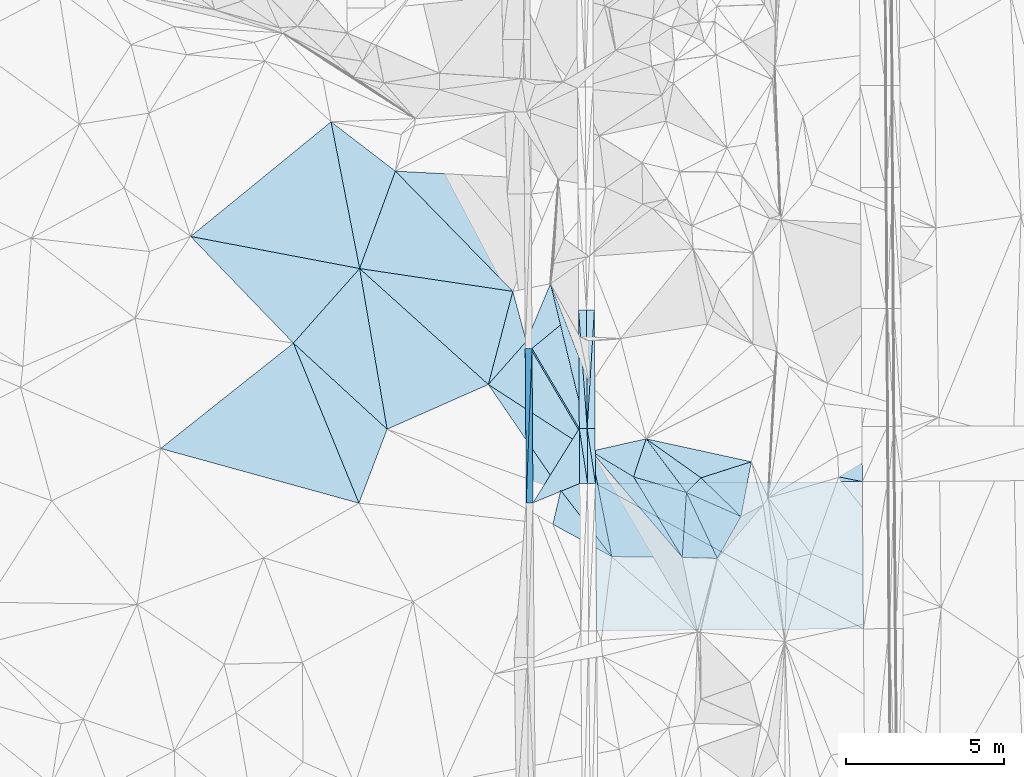
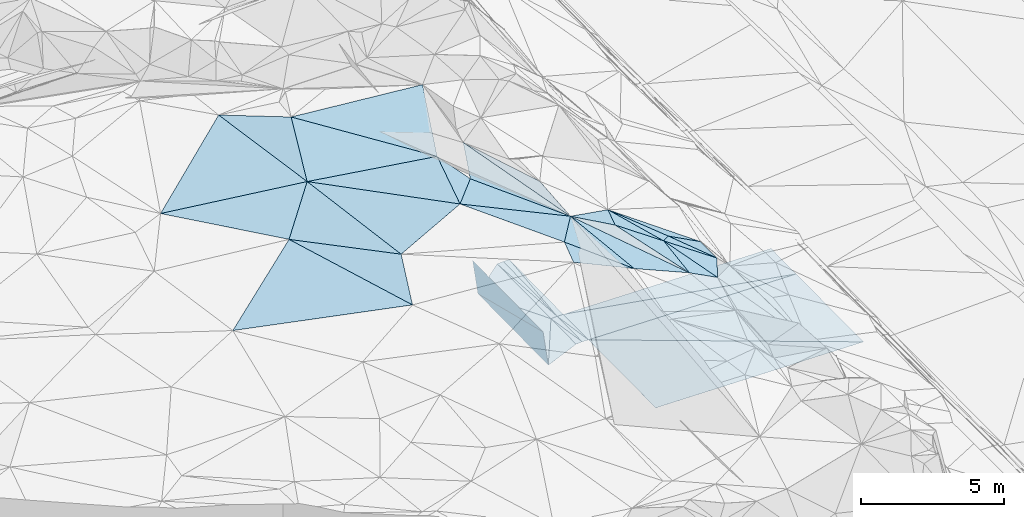
# One storey, part 52 of 275: 45 plates.
"""IFC2X3 building model written with IfcOpenShell, lengths in millimetres."""

from ifc_helpers import new_model, si_unit, frame, origin_with_axes, place, context, subcontext, project, spatial, polyline, outline, extrude, material, type_object, element, save


model = new_model("IFC2X3")

# Units and contexts
model_context = context("Model", 3, precision=1e-05, world=origin_with_axes())
body_context = subcontext(model_context, "Body", "Model", "MODEL_VIEW")
ifc_project = project(units=[si_unit("LENGTHUNIT", "METRE", prefix="MILLI"), si_unit("AREAUNIT", "SQUARE_METRE"), si_unit("VOLUMEUNIT", "CUBIC_METRE"), si_unit("MASSUNIT", "GRAM", prefix="KILO"), si_unit("TIMEUNIT", "SECOND"), si_unit("PLANEANGLEUNIT", "RADIAN"), si_unit("SOLIDANGLEUNIT", "STERADIAN"), si_unit("THERMODYNAMICTEMPERATUREUNIT", "DEGREE_CELSIUS"), si_unit("LUMINOUSINTENSITYUNIT", "LUMEN")], contexts=[model_context])

# Site, building, storey
site_placement = place(None, origin_with_axes())
site = spatial("IfcSite", under=ifc_project, at=site_placement, CompositionType="ELEMENT")
building_placement = place(site_placement, origin_with_axes())
building = spatial("IfcBuilding", under=site, at=building_placement, Name="Undefined", CompositionType="ELEMENT")
storey_placement = place(building_placement, origin_with_axes())
storey = spatial("IfcBuildingStorey", under=building, at=storey_placement, Name="Undefined", CompositionType="ELEMENT", Elevation=0.0)

# Plates
ifc_material = material()
plate_type_1 = type_object("IfcPlateType", PredefinedType="NOTDEFINED")
plate_1_placement = place(storey_placement, frame((-105646.099505865, 40971.8462119818, 43556.70029199), z_axis=(-0.989944103997559, -0.00332123329440851, -0.14142008474709), x_axis=(0.0358624279315071, 0.961171665387579, -0.273610884138268)))
element("IfcPlate", 1, at=plate_1_placement, inside=storey, type_object=plate_type_1, material=ifc_material, Name="00_PR", context=body_context, shape_type="SweptSolid", body=[
    extrude(outline(polyline([(0.0, 0.0), (5083.78515625, -1.32131390273571e-08), (419.531982421875, 1455.99145507813), (0.0, 0.0)])), frame((-8.85201319254618e-08, 2.18876761149539e-07, -0.5000001331573), z_axis=(0.0, 0.0, 1.0), x_axis=(1.0, 0.0, 0.0)), (0.0, 0.0, 1.0), 1.0),
])
plate_2_placement = place(storey_placement, frame((-105463.782624478, 45858.2366308614, 42165.7212907842), z_axis=(-0.989943962731885, -0.00332151817622942, -0.141421066916132), x_axis=(-0.0358624279064692, -0.96117166539395, 0.273610884119171)))
element("IfcPlate", 2, at=plate_2_placement, inside=storey, type_object=plate_type_1, material=ifc_material, Name="00_PR", context=body_context, shape_type="SweptSolid", body=[
    extrude(outline(polyline([(0.0, 0.0), (5083.78515625, -1.32131390273571e-08), (419.365844726563, 1456.03942871094), (0.0, 0.0)])), frame((-8.85201319254618e-08, 2.18876761149539e-07, -0.5000001331573), z_axis=(0.0, 0.0, 1.0), x_axis=(1.0, 0.0, 0.0)), (0.0, 0.0, 1.0), 1.0),
])
plate_type_2 = type_object("IfcPlateType", PredefinedType="NOTDEFINED")
plate_3_placement = place(storey_placement, frame((-103990.523976332, 47065.1459891625, 42193.5847640557), z_axis=(0.0497826913017359, 0.0238959430009052, -0.998474169698372), x_axis=(0.998734720942488, 0.00593198109891951, 0.0499376489652106)))
element("IfcPlate", 3, at=plate_3_placement, inside=storey, type_object=plate_type_2, material=ifc_material, Name="00_PR", context=body_context, shape_type="SweptSolid", body=[
    extrude(outline(polyline([(0.0, 0.0), (250.312118530273, 2.47382558882236e-10), (247.060760498047, 3738.74194335938), (0.0, 0.0)])), frame((-8.85201319254618e-08, 2.18876761149539e-07, -0.5000001331573), z_axis=(0.0, 0.0, 1.0), x_axis=(1.0, 0.0, 0.0)), (0.0, 0.0, 1.0), 1.0),
])
plate_4_placement = place(storey_placement, frame((-103990.523976332, 47065.1459891625, 42193.5847640557), z_axis=(0.049768066755997, 0.0238948883773834, -0.998474923991986), x_axis=(0.0729547701272873, -0.997130130226258, -0.0202263419985308)))
element("IfcPlate", 4, at=plate_4_placement, inside=storey, type_object=plate_type_2, material=ifc_material, Name="00_PR", context=body_context, shape_type="SweptSolid", body=[
    extrude(outline(polyline([(0.0, 0.0), (3746.89599609375, 9.83709469437599e-09), (3730.54565429688, 249.77783203125), (0.0, 0.0)])), frame((-8.85201319254618e-08, 2.18876761149539e-07, -0.5000001331573), z_axis=(0.0, 0.0, 1.0), x_axis=(1.0, 0.0, 0.0)), (0.0, 0.0, 1.0), 1.0),
])
plate_5_placement = place(storey_placement, frame((-103967.16475753, 43327.3619378726, 42105.2987347307), z_axis=(0.0497883116718001, 0.0212555803372837, -0.998533586979125), x_axis=(0.998730855208098, 0.00655097410648451, 0.0499375969942156)))
element("IfcPlate", 5, at=plate_5_placement, inside=storey, type_object=plate_type_2, material=ifc_material, Name="00_PR", context=body_context, shape_type="SweptSolid", body=[
    extrude(outline(polyline([(0.0, 0.0), (250.312408447266, 1.29512045532465e-09), (248.740264892578, 1744.41296386719), (0.0, 0.0)])), frame((-8.85201319254618e-08, 2.18876761149539e-07, -0.5000001331573), z_axis=(0.0, 0.0, 1.0), x_axis=(1.0, 0.0, 0.0)), (0.0, 0.0, 1.0), 1.0),
])
plate_6_placement = place(storey_placement, frame((-103717.204999784, 43329.0015019707, 42117.7982104871), z_axis=(-0.0201285348470249, 0.0208096383223424, -0.99958081265989), x_axis=(0.999778552913114, 0.00655785011376735, -0.0199959930197069)))
element("IfcPlate", 6, at=plate_6_placement, inside=storey, type_object=plate_type_2, material=ifc_material, Name="00_PR", context=body_context, shape_type="SweptSolid", body=[
    extrude(outline(polyline([(0.0, 0.0), (250.050094604492, -1.09139364212751e-09), (251.033966064453, 1744.34130859375), (0.0, 0.0)])), frame((-8.85201319254618e-08, 2.18876761149539e-07, -0.5000001331573), z_axis=(0.0, 0.0, 1.0), x_axis=(1.0, 0.0, 0.0)), (0.0, 0.0, 1.0), 1.0),
])
plate_7_placement = place(storey_placement, frame((-103490.567670264, 47068.1145608061, 42201.0842400779), z_axis=(-0.0201301595601197, 0.0234837584701815, -0.999521530415528), x_axis=(-0.0604866279020692, -0.997921482323828, -0.0222279770030963)))
element("IfcPlate", 7, at=plate_7_placement, inside=storey, type_object=plate_type_2, material=ifc_material, Name="00_PR", context=body_context, shape_type="SweptSolid", body=[
    extrude(outline(polyline([(0.0, 0.0), (3746.89965820313, -5.96628524363041e-09), (16.4911136627197, 249.505844116211), (0.0, 0.0)])), frame((-8.85201319254618e-08, 2.18876761149539e-07, -0.5000001331573), z_axis=(0.0, 0.0, 1.0), x_axis=(1.0, 0.0, 0.0)), (0.0, 0.0, 1.0), 1.0),
])
plate_8_placement = place(storey_placement, frame((-103717.205004807, 43329.0028402854, 42117.7982401176), z_axis=(-0.0201448896298397, 0.0234846442214131, -0.999521212835223), x_axis=(0.0604866278932027, 0.997921482324426, 0.0222279770003913)))
element("IfcPlate", 8, at=plate_8_placement, inside=storey, type_object=plate_type_2, material=ifc_material, Name="00_PR", context=body_context, shape_type="SweptSolid", body=[
    extrude(outline(polyline([(0.0, 0.0), (3746.89965820313, -5.96628524363041e-09), (16.6465797424316, 249.495376586914), (0.0, 0.0)])), frame((-8.85201319254618e-08, 2.18876761149539e-07, -0.5000001331573), z_axis=(0.0, 0.0, 1.0), x_axis=(1.0, 0.0, 0.0)), (0.0, 0.0, 1.0), 1.0),
])
plate_9_placement = place(storey_placement, frame((-103455.518130814, 41586.7216911153, 42076.2572102643), z_axis=(-0.0201345410641889, 0.0208087343457324, -0.999580710513695), x_axis=(-0.999776620871527, -0.00684613913005183, 0.0199959680366688)))
element("IfcPlate", 9, at=plate_9_placement, inside=storey, type_object=plate_type_2, material=ifc_material, Name="00_PR", context=body_context, shape_type="SweptSolid", body=[
    extrude(outline(polyline([(0.0, 0.0), (250.050399780273, 6.83940015733242e-10), (250.531173706055, 1744.41357421875), (0.0, 0.0)])), frame((-8.85201319254618e-08, 2.18876761149539e-07, -0.5000001331573), z_axis=(0.0, 0.0, 1.0), x_axis=(1.0, 0.0, 0.0)), (0.0, 0.0, 1.0), 1.0),
])
plate_type_3 = type_object("IfcPlateType", PredefinedType="NOTDEFINED")
plate_10_placement = place(storey_placement, frame((-102939.146189244, 39270.7353602153, 46349.5065492143), z_axis=(-0.0826053856121909, 0.138808484605997, -0.986868053424189), x_axis=(-0.867752438274442, 0.476952593334072, 0.13972089886865)))
element("IfcPlate", 10, at=plate_10_placement, inside=storey, type_object=plate_type_3, material=ifc_material, Name="00", context=body_context, shape_type="SweptSolid", body=[
    extrude(outline(polyline([(0.0, 0.0), (2147.1376953125, -1.00590114016086e-09), (2461.41650390625, 1062.13403320313), (0.0, 0.0)])), frame((-8.85201319254618e-08, 2.18876761149539e-07, -0.5000001331573), z_axis=(0.0, 0.0, 1.0), x_axis=(1.0, 0.0, 0.0)), (0.0, 0.0, 1.0), 1.0),
])
plate_type_4 = type_object("IfcPlateType", PredefinedType="NOTDEFINED")
plate_11_placement = place(storey_placement, frame((-110915.037388213, 48383.8786528723, 47339.5012897801), z_axis=(0.0226269542066406, 0.068628935059666, -0.997385627636526), x_axis=(0.742622411281984, -0.66907387332103, -0.0291908598867195)))
element("IfcPlate", 11, at=plate_11_placement, inside=storey, type_object=plate_type_4, material=ifc_material, Name="00", context=body_context, shape_type="SweptSolid", body=[
    extrude(outline(polyline([(0.0, 0.0), (5481.16796875, -2.38287611864507e-08), (4055.77807617188, 3201.119140625), (0.0, 0.0)])), frame((-8.85201319254618e-08, 2.18876761149539e-07, -0.5000001331573), z_axis=(0.0, 0.0, 1.0), x_axis=(1.0, 0.0, 0.0)), (0.0, 0.0, 1.0), 1.0),
])
plate_type_5 = type_object("IfcPlateType", PredefinedType="NOTDEFINED")
plate_12_placement = place(storey_placement, frame((-105431.325757645, 40973.3478867725, 42056.2711269941), z_axis=(-0.0023716211679166, 0.0222968232700742, -0.999748581937028), x_axis=(-0.00654147009644607, 0.999729657177308, 0.0223119189923385)))
element("IfcPlate", 12, at=plate_12_placement, inside=storey, type_object=plate_type_5, material=ifc_material, Name="00_PR", context=body_context, shape_type="SweptSolid", body=[
    extrude(outline(polyline([(0.0, 0.0), (4886.22265625, 8.78935679793358e-09), (2344.89453125, 1479.509765625), (0.0, 0.0)])), frame((-8.85201319254618e-08, 2.18876761149539e-07, -0.5000001331573), z_axis=(0.0, 0.0, 1.0), x_axis=(1.0, 0.0, 0.0)), (0.0, 0.0, 1.0), 1.0),
])
plate_13_placement = place(storey_placement, frame((-105463.287724358, 45858.2500991869, 42165.2921410413), z_axis=(-0.000145026307554979, 0.0236123931932883, -0.99972117805669), x_axis=(0.773375530053291, 0.633774062177559, 0.0148569049854867)))
element("IfcPlate", 13, at=plate_13_placement, inside=storey, type_object=plate_type_5, material=ifc_material, Name="00_PR", context=body_context, shape_type="SweptSolid", body=[
    extrude(outline(polyline([(0.0, 0.0), (1904.29968261719, -4.26371116191149e-09), (-447.856262207031, 2906.32446289063), (0.0, 0.0)])), frame((-8.85201319254618e-08, 2.18876761149539e-07, -0.5000001331573), z_axis=(0.0, 0.0, 1.0), x_axis=(1.0, 0.0, 0.0)), (0.0, 0.0, 1.0), 1.0),
])
plate_type_6 = type_object("IfcPlateType", PredefinedType="NOTDEFINED")
plate_14_placement = place(storey_placement, frame((-103705.477725775, 41585.010034018, 42081.2577343795), z_axis=(0.0497822401584347, 0.0212546735396291, -0.998533908997352), x_axis=(-0.998728898729701, -0.00684263509403979, -0.0499376129498451)))
element("IfcPlate", 14, at=plate_14_placement, inside=storey, type_object=plate_type_6, material=ifc_material, Name="00_PR", context=body_context, shape_type="SweptSolid", body=[
    extrude(outline(polyline([(0.0, 0.0), (250.31233215332, -1.60071067512035e-10), (248.231567382813, 1744.4853515625), (0.0, 0.0)])), frame((-8.85201319254618e-08, 2.18876761149539e-07, -0.5000001331573), z_axis=(0.0, 0.0, 1.0), x_axis=(1.0, 0.0, 0.0)), (0.0, 0.0, 1.0), 1.0),
])
plate_type_7 = type_object("IfcPlateType", PredefinedType="NOTDEFINED")
plate_15_placement = place(storey_placement, frame((-103955.496871295, 41583.297085441, 42068.7571113255), z_axis=(-0.00019824100908301, 0.0209457045336442, -0.999780595011771), x_axis=(-0.924151662952956, -0.381945772098583, -0.00781863397933819)))
element("IfcPlate", 15, at=plate_15_placement, inside=storey, type_object=plate_type_7, material=ifc_material, Name="00_PR", context=body_context, shape_type="SweptSolid", body=[
    extrude(outline(polyline([(0.0, 0.0), (1596.9541015625, 1.13359419628978e-08), (-655.617858886719, 1616.60107421875), (0.0, 0.0)])), frame((-8.85201319254618e-08, 2.18876761149539e-07, -0.5000001331573), z_axis=(0.0, 0.0, 1.0), x_axis=(1.0, 0.0, 0.0)), (0.0, 0.0, 1.0), 1.0),
])
plate_type_8 = type_object("IfcPlateType", PredefinedType="NOTDEFINED")
plate_16_placement = place(storey_placement, frame((-103467.210276202, 43330.641308768, 42112.7982102375), z_axis=(-0.0201313758675442, 0.0208385412725636, -0.999580153316037), x_axis=(0.999778365282189, 0.00657969213106118, -0.019998199047256)))
element("IfcPlate", 16, at=plate_16_placement, inside=storey, type_object=plate_type_8, material=ifc_material, Name="00_PR", context=body_context, shape_type="SweptSolid", body=[
    extrude(outline(polyline([(0.0, 0.0), (8443.5107421875, -3.54120857082307e-08), (8444.4931640625, 1741.89990234375), (0.0, 0.0)])), frame((-8.85201319254618e-08, 2.18876761149539e-07, -0.5000001331573), z_axis=(0.0, 0.0, 1.0), x_axis=(1.0, 0.0, 0.0)), (0.0, 0.0, 1.0), 1.0),
])
plate_type_9 = type_object("IfcPlateType", PredefinedType="NOTDEFINED")
plate_17_placement = place(storey_placement, frame((-95013.8578508624, 41644.7195649811, 41907.4022094832), z_axis=(-0.0201371647296545, 0.0208095774220167, -0.999580640110726), x_axis=(-0.999776421923135, -0.00686889812441392, 0.0199981100389784)))
element("IfcPlate", 17, at=plate_17_placement, inside=storey, type_object=plate_type_9, material=ifc_material, Name="00_PR", context=body_context, shape_type="SweptSolid", body=[
    extrude(outline(polyline([(0.0, 0.0), (8443.5478515625, -4.53292159363627e-09), (8443.9892578125, 1744.34155273438), (0.0, 0.0)])), frame((-8.85201319254618e-08, 2.18876761149539e-07, -0.5000001331573), z_axis=(0.0, 0.0, 1.0), x_axis=(1.0, 0.0, 0.0)), (0.0, 0.0, 1.0), 1.0),
])
plate_type_10 = type_object("IfcPlateType", PredefinedType="NOTDEFINED")
plate_18_placement = place(storey_placement, frame((-103455.518128, 41586.7214102786, 42076.2572045192), z_axis=(-0.0201337158905751, 0.0202754336875797, -0.999591686776765), x_axis=(0.999776421923209, 0.00686889811770438, -0.0199981100375734)))
element("IfcPlate", 18, at=plate_18_placement, inside=storey, type_object=plate_type_10, material=ifc_material, Name="00_PR", context=body_context, shape_type="SweptSolid", body=[
    extrude(outline(polyline([(0.0, 0.0), (8443.5478515625, -4.53292159363627e-09), (8447.2509765625, 4657.70166015625), (0.0, 0.0)])), frame((-8.85201319254618e-08, 2.18876761149539e-07, -0.5000001331573), z_axis=(0.0, 0.0, 1.0), x_axis=(1.0, 0.0, 0.0)), (0.0, 0.0, 1.0), 1.0),
])
plate_type_11 = type_object("IfcPlateType", PredefinedType="NOTDEFINED")
plate_19_placement = place(storey_placement, frame((-94980.0641760851, 36988.1104912917, 41812.2682041241), z_axis=(-0.0201490656662362, 0.0202471591356231, -0.9995919505977), x_axis=(-0.999770813898396, -0.00764230011555807, 0.0199978730339621)))
element("IfcPlate", 19, at=plate_19_placement, inside=storey, type_object=plate_type_11, material=ifc_material, Name="00_PR", context=body_context, shape_type="SweptSolid", body=[
    extrude(outline(polyline([(0.0, 0.0), (8443.6484375, -4.91054379381239e-08), (8443.646484375, 4664.232421875), (0.0, 0.0)])), frame((-8.85201319254618e-08, 2.18876761149539e-07, -0.5000001331573), z_axis=(0.0, 0.0, 1.0), x_axis=(1.0, 0.0, 0.0)), (0.0, 0.0, 1.0), 1.0),
])
plate_type_12 = type_object("IfcPlateType", PredefinedType="NOTDEFINED")
plate_20_placement = place(storey_placement, frame((-99601.987935928, 39215.4092366922, 44839.5540066472), z_axis=(-0.447516226942144, 0.0644141312208133, -0.891952939522336), x_axis=(-0.892551521334942, 0.0297356425134364, 0.449963968920839)))
element("IfcPlate", 20, at=plate_20_placement, inside=storey, type_object=plate_type_12, material=ifc_material, Name="00", context=body_context, shape_type="SweptSolid", body=[
    extrude(outline(polyline([(0.0, 0.0), (1244.54406738281, 1.73895386978984e-09), (1220.80847167969, 2052.24926757813), (0.0, 0.0)])), frame((-8.85201319254618e-08, 2.18876761149539e-07, -0.5000001331573), z_axis=(0.0, 0.0, 1.0), x_axis=(1.0, 0.0, 0.0)), (0.0, 0.0, 1.0), 1.0),
])
plate_type_13 = type_object("IfcPlateType", PredefinedType="NOTDEFINED")
plate_21_placement = place(storey_placement, frame((-103593.456947714, 42605.9050386821, 46795.5119502984), z_axis=(0.183013277644994, 0.117345003392869, -0.976082112521464), x_axis=(-0.235075345137034, 0.96927319876062, 0.0724503158934495)))
element("IfcPlate", 21, at=plate_21_placement, inside=storey, type_object=plate_type_13, material=ifc_material, Name="00", context=body_context, shape_type="SweptSolid", body=[
    extrude(outline(polyline([(0.0, 0.0), (5465.814453125, -2.20607034862041e-08), (2050.4755859375, 465.629974365234), (0.0, 0.0)])), frame((-8.85201319254618e-08, 2.18876761149539e-07, -0.5000001331573), z_axis=(0.0, 0.0, 1.0), x_axis=(1.0, 0.0, 0.0)), (0.0, 0.0, 1.0), 1.0),
])
plate_type_14 = type_object("IfcPlateType", PredefinedType="NOTDEFINED")
plate_22_placement = place(storey_placement, frame((-113010.220664172, 46025.3122593773, 47029.5085310838), z_axis=(0.120941204718582, 0.138842368146875, -0.982901837320791), x_axis=(0.736351800275716, -0.676580629319015, -0.00496772191231505)))
element("IfcPlate", 22, at=plate_22_placement, inside=storey, type_object=plate_type_14, material=ifc_material, Name="00", context=body_context, shape_type="SweptSolid", body=[
    extrude(outline(polyline([(0.0, 0.0), (4025.99047851563, 1.808803062886e-08), (4955.798828125, 2365.38720703125), (0.0, 0.0)])), frame((-8.85201319254618e-08, 2.18876761149539e-07, -0.5000001331573), z_axis=(0.0, 0.0, 1.0), x_axis=(1.0, 0.0, 0.0)), (0.0, 0.0, 1.0), 1.0),
])
plate_type_15 = type_object("IfcPlateType", PredefinedType="NOTDEFINED")
plate_23_placement = place(storey_placement, frame((-101853.728161973, 42997.9207174369, 46229.5619633326), z_axis=(-0.481556525705303, 0.0250567148859988, -0.876056775323243), x_axis=(0.739455480286452, -0.524936105995372, -0.421482712927528)))
element("IfcPlate", 23, at=plate_23_placement, inside=storey, type_object=plate_type_15, material=ifc_material, Name="00", context=body_context, shape_type="SweptSolid", body=[
    extrude(outline(polyline([(0.0, 0.0), (2348.85083007813, 1.3249518815428e-08), (2151.60546875, 669.622497558594), (0.0, 0.0)])), frame((-8.85201319254618e-08, 2.18876761149539e-07, -0.5000001331573), z_axis=(0.0, 0.0, 1.0), x_axis=(1.0, 0.0, 0.0)), (0.0, 0.0, 1.0), 1.0),
])
plate_type_16 = type_object("IfcPlateType", PredefinedType="NOTDEFINED")
plate_24_placement = place(storey_placement, frame((-104878.4079931, 47903.755833042, 47191.5020870339), z_axis=(0.0376161793898115, 0.083555540950583, -0.995792897456378), x_axis=(0.235075345621181, -0.969273198636833, -0.0724503159786341)))
element("IfcPlate", 24, at=plate_24_placement, inside=storey, type_object=plate_type_16, material=ifc_material, Name="00", context=body_context, shape_type="SweptSolid", body=[
    extrude(outline(polyline([(0.0, 0.0), (5465.814453125, -2.20607034862041e-08), (1602.33227539063, 1174.82958984375), (0.0, 0.0)])), frame((-8.85201319254618e-08, 2.18876761149539e-07, -0.5000001331573), z_axis=(0.0, 0.0, 1.0), x_axis=(1.0, 0.0, 0.0)), (0.0, 0.0, 1.0), 1.0),
])
plate_type_17 = type_object("IfcPlateType", PredefinedType="NOTDEFINED")
plate_25_placement = place(storey_placement, frame((-106844.646991197, 44716.5727714059, 47179.5025034906), z_axis=(-0.0726241352308983, 0.0691520847019634, -0.994959157032758), x_axis=(0.834652229437488, -0.541882481464694, -0.0985851519078647)))
element("IfcPlate", 25, at=plate_25_placement, inside=storey, type_object=plate_type_17, material=ifc_material, Name="00", context=body_context, shape_type="SweptSolid", body=[
    extrude(outline(polyline([(0.0, 0.0), (3895.10986328125, -8.5165083874017e-09), (3766.248046875, 1563.03405761719), (0.0, 0.0)])), frame((-8.85201319254618e-08, 2.18876761149539e-07, -0.5000001331573), z_axis=(0.0, 0.0, 1.0), x_axis=(1.0, 0.0, 0.0)), (0.0, 0.0, 1.0), 1.0),
])
plate_type_18 = type_object("IfcPlateType", PredefinedType="NOTDEFINED")
plate_26_placement = place(storey_placement, frame((-100712.596946371, 39252.566749328, 45399.5346439763), z_axis=(-0.0262935744330471, 0.364847100760417, -0.930696105616786), x_axis=(-0.621404577992663, 0.723319066716412, 0.301107751767136)))
element("IfcPlate", 26, at=plate_26_placement, inside=storey, type_object=plate_type_18, material=ifc_material, Name="00", context=body_context, shape_type="SweptSolid", body=[
    extrude(outline(polyline([(0.0, 0.0), (4636.2138671875, -2.7212081477046e-09), (3107.76953125, 501.815063476563), (0.0, 0.0)])), frame((-8.85201319254618e-08, 2.18876761149539e-07, -0.5000001331573), z_axis=(0.0, 0.0, 1.0), x_axis=(1.0, 0.0, 0.0)), (0.0, 0.0, 1.0), 1.0),
])
plate_type_19 = type_object("IfcPlateType", PredefinedType="NOTDEFINED")
plate_27_placement = place(storey_placement, frame((-98854.1244597753, 40540.9655843299, 44599.5552423308), z_axis=(-0.456892653692236, -0.00624859166700667, -0.88949989213279), x_axis=(-0.829319588943055, 0.364616043801481, 0.423419602755799)))
element("IfcPlate", 27, at=plate_27_placement, inside=storey, type_object=plate_type_19, material=ifc_material, Name="00", context=body_context, shape_type="SweptSolid", body=[
    extrude(outline(polyline([(0.0, 0.0), (2078.31665039063, 1.24623511510435e-08), (1764.45678710938, 623.531921386719), (0.0, 0.0)])), frame((-8.85201319254618e-08, 2.18876761149539e-07, -0.5000001331573), z_axis=(0.0, 0.0, 1.0), x_axis=(1.0, 0.0, 0.0)), (0.0, 0.0, 1.0), 1.0),
])
plate_type_20 = type_object("IfcPlateType", PredefinedType="NOTDEFINED")
plate_28_placement = place(storey_placement, frame((-100577.732183419, 41298.7621970565, 45479.5655734672), z_axis=(-0.494957902070171, 0.0118058618870403, -0.868836749224731), x_axis=(-0.840098297184469, 0.248880817905309, 0.481968037888967)))
element("IfcPlate", 28, at=plate_28_placement, inside=storey, type_object=plate_type_20, material=ifc_material, Name="00", context=body_context, shape_type="SweptSolid", body=[
    extrude(outline(polyline([(0.0, 0.0), (1991.83337402344, 8.8020897237584e-09), (1856.330078125, 1277.43444824219), (0.0, 0.0)])), frame((-8.85201319254618e-08, 2.18876761149539e-07, -0.5000001331573), z_axis=(0.0, 0.0, 1.0), x_axis=(1.0, 0.0, 0.0)), (0.0, 0.0, 1.0), 1.0),
])
plate_type_21 = type_object("IfcPlateType", PredefinedType="NOTDEFINED")
plate_29_placement = place(storey_placement, frame((-98525.8593509955, 42271.4435231601, 44139.5835246986), z_axis=(-0.544565240447849, -0.0983242847066925, -0.83293519191645), x_axis=(-0.795713819635988, -0.253353885984469, 0.550137551614935)))
element("IfcPlate", 29, at=plate_29_placement, inside=storey, type_object=plate_type_21, material=ifc_material, Name="00", context=body_context, shape_type="SweptSolid", body=[
    extrude(outline(polyline([(0.0, 0.0), (1999.49987792969, 5.2677933126688e-09), (3613.80346679688, 1706.20153808594), (0.0, 0.0)])), frame((-8.85201319254618e-08, 2.18876761149539e-07, -0.5000001331573), z_axis=(0.0, 0.0, 1.0), x_axis=(1.0, 0.0, 0.0)), (0.0, 0.0, 1.0), 1.0),
])
plate_type_22 = type_object("IfcPlateType", PredefinedType="NOTDEFINED")
plate_30_placement = place(storey_placement, frame((-100577.697808599, 41298.7949297474, 45479.5493322777), z_axis=(-0.426207177614087, 0.0772712205311199, -0.901319366388998), x_axis=(0.829319588943677, -0.364616043799035, -0.423419602756688)))
element("IfcPlate", 30, at=plate_30_placement, inside=storey, type_object=plate_type_22, material=ifc_material, Name="00", context=body_context, shape_type="SweptSolid", body=[
    extrude(outline(polyline([(0.0, 0.0), (2078.31665039063, 1.24623511510435e-08), (1839.80627441406, 1522.23937988281), (0.0, 0.0)])), frame((-8.85201319254618e-08, 2.18876761149539e-07, -0.5000001331573), z_axis=(0.0, 0.0, 1.0), x_axis=(1.0, 0.0, 0.0)), (0.0, 0.0, 1.0), 1.0),
])
plate_type_23 = type_object("IfcPlateType", PredefinedType="NOTDEFINED")
plate_31_placement = place(storey_placement, frame((-100712.824682636, 39252.4173089587, 45399.5630857787), z_axis=(-0.481767490475847, 0.0659661904628343, -0.873812649734727), x_axis=(-0.488635756248173, 0.807522983042371, 0.330366053907066)))
element("IfcPlate", 31, at=plate_31_placement, inside=storey, type_object=plate_type_23, material=ifc_material, Name="00", context=body_context, shape_type="SweptSolid", body=[
    extrude(outline(polyline([(0.0, 0.0), (3148.02319335938, -1.11758708953857e-08), (1612.90747070313, 1269.1806640625), (0.0, 0.0)])), frame((-8.85201319254618e-08, 2.18876761149539e-07, -0.5000001331573), z_axis=(0.0, 0.0, 1.0), x_axis=(1.0, 0.0, 0.0)), (0.0, 0.0, 1.0), 1.0),
])
plate_type_24 = type_object("IfcPlateType", PredefinedType="NOTDEFINED")
plate_32_placement = place(storey_placement, frame((-102250.967724056, 41794.4508510376, 46439.523412018), z_axis=(-0.294469647980331, -0.0691036241414694, -0.953159123939363), x_axis=(-0.834659172058475, 0.504353739839719, 0.221294761818598)))
element("IfcPlate", 32, at=plate_32_placement, inside=storey, type_object=plate_type_24, material=ifc_material, Name="00", context=body_context, shape_type="SweptSolid", body=[
    extrude(outline(polyline([(0.0, 0.0), (1608.71411132813, 9.13860276341438e-09), (228.841156005859, 1264.0537109375), (0.0, 0.0)])), frame((-8.85201319254618e-08, 2.18876761149539e-07, -0.5000001331573), z_axis=(0.0, 0.0, 1.0), x_axis=(1.0, 0.0, 0.0)), (0.0, 0.0, 1.0), 1.0),
])
plate_type_25 = type_object("IfcPlateType", PredefinedType="NOTDEFINED")
plate_33_placement = place(storey_placement, frame((-103593.744392885, 42605.8693983916, 46795.5405145625), z_axis=(-0.391709323107848, 0.0460228003492878, -0.918937271002978), x_axis=(0.621404578383987, -0.723319066349594, -0.301107751840716)))
element("IfcPlate", 33, at=plate_33_placement, inside=storey, type_object=plate_type_25, material=ifc_material, Name="00", context=body_context, shape_type="SweptSolid", body=[
    extrude(outline(polyline([(0.0, 0.0), (4636.2138671875, -2.7212081477046e-09), (2953.36791992188, 1740.18933105469), (0.0, 0.0)])), frame((-8.85201319254618e-08, 2.18876761149539e-07, -0.5000001331573), z_axis=(0.0, 0.0, 1.0), x_axis=(1.0, 0.0, 0.0)), (0.0, 0.0, 1.0), 1.0),
])
plate_type_26 = type_object("IfcPlateType", PredefinedType="NOTDEFINED")
plate_34_placement = place(storey_placement, frame((-106069.28839193, 47661.5773674918, 47159.5092758969), z_axis=(-0.187115881875896, 0.0426022361486181, -0.981413621377319), x_axis=(0.259039019761514, -0.961558300196776, -0.0911285990437723)))
element("IfcPlate", 34, at=plate_34_placement, inside=storey, type_object=plate_type_26, material=ifc_material, Name="00", context=body_context, shape_type="SweptSolid", body=[
    extrude(outline(polyline([(0.0, 0.0), (1646.02551269531, -1.84809323400259e-09), (2629.12084960938, 1537.05029296875), (0.0, 0.0)])), frame((-8.85201319254618e-08, 2.18876761149539e-07, -0.5000001331573), z_axis=(0.0, 0.0, 1.0), x_axis=(1.0, 0.0, 0.0)), (0.0, 0.0, 1.0), 1.0),
])
plate_type_27 = type_object("IfcPlateType", PredefinedType="NOTDEFINED")
plate_35_placement = place(storey_placement, frame((-104554.531776825, 41366.5238184583, 46779.5066993069), z_axis=(-0.12268353600863, 0.107856152116877, -0.986567686701202), x_axis=(0.612701154335467, 0.790248832289336, 0.0102018891058475)))
element("IfcPlate", 35, at=plate_35_placement, inside=storey, type_object=plate_type_27, material=ifc_material, Name="00", context=body_context, shape_type="SweptSolid", body=[
    extrude(outline(polyline([(0.0, 0.0), (1568.33703613281, 1.06228981167078e-09), (-670.857055664063, 2595.505859375), (0.0, 0.0)])), frame((-8.85201319254618e-08, 2.18876761149539e-07, -0.5000001331573), z_axis=(0.0, 0.0, 1.0), x_axis=(1.0, 0.0, 0.0)), (0.0, 0.0, 1.0), 1.0),
])
plate_type_28 = type_object("IfcPlateType", PredefinedType="NOTDEFINED")
plate_36_placement = place(storey_placement, frame((-98854.1654065552, 40540.9089655787, 44599.5829572672), z_axis=(-0.538585734589536, -0.119524747118234, -0.834049903376874), x_axis=(-0.674750256838677, 0.654028818000486, 0.341991807096348)))
element("IfcPlate", 36, at=plate_36_placement, inside=storey, type_object=plate_type_28, material=ifc_material, Name="00", context=body_context, shape_type="SweptSolid", body=[
    extrude(outline(polyline([(0.0, 0.0), (1871.38989257813, -3.80532583221793e-09), (752.969787597656, 1657.44885253906), (0.0, 0.0)])), frame((-8.85201319254618e-08, 2.18876761149539e-07, -0.5000001331573), z_axis=(0.0, 0.0, 1.0), x_axis=(1.0, 0.0, 0.0)), (0.0, 0.0, 1.0), 1.0),
])
plate_type_29 = type_object("IfcPlateType", PredefinedType="NOTDEFINED")
plate_37_placement = place(storey_placement, frame((-111818.717097663, 53024.7851868217, 47689.5019866313), z_axis=(0.0360771079713755, 0.0821373336306262, -0.995967821118972), x_axis=(0.190610858689938, -0.978885850933483, -0.0738240569984904)))
element("IfcPlate", 37, at=plate_37_placement, inside=storey, type_object=plate_type_29, material=ifc_material, Name="00", context=body_context, shape_type="SweptSolid", body=[
    extrude(outline(polyline([(0.0, 0.0), (4741.001953125, 6.92671164870262e-09), (2736.69995117188, 5060.9658203125), (0.0, 0.0)])), frame((-8.85201319254618e-08, 2.18876761149539e-07, -0.5000001331573), z_axis=(0.0, 0.0, 1.0), x_axis=(1.0, 0.0, 0.0)), (0.0, 0.0, 1.0), 1.0),
])
plate_type_30 = type_object("IfcPlateType", PredefinedType="NOTDEFINED")
plate_38_placement = place(storey_placement, frame((-116261.891087616, 49398.5693058583, 47229.5026724019), z_axis=(0.03873861053166, 0.0963107723748093, -0.994597182370151), x_axis=(0.982265148170861, -0.186404981354345, 0.0202079592033122)))
element("IfcPlate", 38, at=plate_38_placement, inside=storey, type_object=plate_type_30, material=ifc_material, Name="00", context=body_context, shape_type="SweptSolid", body=[
    extrude(outline(polyline([(0.0, 0.0), (5443.39990234375, -5.86078385822475e-09), (3818.71655273438, 2722.04052734375), (0.0, 0.0)])), frame((-8.85201319254618e-08, 2.18876761149539e-07, -0.5000001331573), z_axis=(0.0, 0.0, 1.0), x_axis=(1.0, 0.0, 0.0)), (0.0, 0.0, 1.0), 1.0),
])
plate_type_31 = type_object("IfcPlateType", PredefinedType="NOTDEFINED")
plate_39_placement = place(storey_placement, frame((-103593.611333516, 42605.8398923652, 46795.5039855406), z_axis=(-0.125601292720201, -0.0129868432499396, -0.99199579493535), x_axis=(-0.834652229433491, 0.541882481469705, 0.0985851519141594)))
element("IfcPlate", 39, at=plate_39_placement, inside=storey, type_object=plate_type_31, material=ifc_material, Name="00", context=body_context, shape_type="SweptSolid", body=[
    extrude(outline(polyline([(0.0, 0.0), (3895.10986328125, -8.5165083874017e-09), (3613.4541015625, 1802.68408203125), (0.0, 0.0)])), frame((-8.85201319254618e-08, 2.18876761149539e-07, -0.5000001331573), z_axis=(0.0, 0.0, 1.0), x_axis=(1.0, 0.0, 0.0)), (0.0, 0.0, 1.0), 1.0),
])
plate_type_32 = type_object("IfcPlateType", PredefinedType="NOTDEFINED")
plate_40_placement = place(storey_placement, frame((-110045.704504048, 43301.3732606974, 47009.5023812845), z_axis=(0.0624764719898047, 0.0753029942377692, -0.995201562250851), x_axis=(-0.736351800293318, 0.676580629299888, 0.00496772190821961)))
element("IfcPlate", 40, at=plate_40_placement, inside=storey, type_object=plate_type_32, material=ifc_material, Name="00", context=body_context, shape_type="SweptSolid", body=[
    extrude(outline(polyline([(0.0, 0.0), (4025.99047851563, 1.808803062886e-08), (4080.48657226563, 3169.56298828125), (0.0, 0.0)])), frame((-8.85201319254618e-08, 2.18876761149539e-07, -0.5000001331573), z_axis=(0.0, 0.0, 1.0), x_axis=(1.0, 0.0, 0.0)), (0.0, 0.0, 1.0), 1.0),
])
plate_type_33 = type_object("IfcPlateType", PredefinedType="NOTDEFINED")
plate_41_placement = place(storey_placement, frame((-106844.629026499, 44716.5396317869, 47179.5003216953), z_axis=(-0.0366915724507592, 0.00287427038347074, -0.999322504040039), x_axis=(-0.74262241127208, 0.669073873330794, 0.0291908599148759)))
element("IfcPlate", 41, at=plate_41_placement, inside=storey, type_object=plate_type_33, material=ifc_material, Name="00", context=body_context, shape_type="SweptSolid", body=[
    extrude(outline(polyline([(0.0, 0.0), (5481.16796875, -2.38287611864507e-08), (1394.00952148438, 2707.68115234375), (0.0, 0.0)])), frame((-8.85201319254618e-08, 2.18876761149539e-07, -0.5000001331573), z_axis=(0.0, 0.0, 1.0), x_axis=(1.0, 0.0, 0.0)), (0.0, 0.0, 1.0), 1.0),
])
plate_type_34 = type_object("IfcPlateType", PredefinedType="NOTDEFINED")
plate_42_placement = place(storey_placement, frame((-109783.91925129, 51464.272496673, 47839.5085228584), z_axis=(0.152014188712373, 0.103728853908978, -0.982920144923711), x_axis=(-0.340746763513914, -0.928009428657994, -0.150632478160111)))
element("IfcPlate", 42, at=plate_42_placement, inside=storey, type_object=plate_type_34, material=ifc_material, Name="00", context=body_context, shape_type="SweptSolid", body=[
    extrude(outline(polyline([(0.0, 0.0), (3319.33740234375, -1.50903360918164e-08), (-732.254577636719, 2462.052734375), (0.0, 0.0)])), frame((-8.85201319254618e-08, 2.18876761149539e-07, -0.5000001331573), z_axis=(0.0, 0.0, 1.0), x_axis=(1.0, 0.0, 0.0)), (0.0, 0.0, 1.0), 1.0),
])
plate_type_35 = type_object("IfcPlateType", PredefinedType="NOTDEFINED")
plate_43_placement = place(storey_placement, frame((-106069.20089142, 47661.6383373138, 47159.5068352318), z_axis=(-0.0121109181066604, 0.164540318536855, -0.986296004878051), x_axis=(-0.988406520005123, 0.147324796315718, 0.0367145148666745)))
element("IfcPlate", 43, at=plate_43_placement, inside=storey, type_object=plate_type_35, material=ifc_material, Name="00", context=body_context, shape_type="SweptSolid", body=[
    extrude(outline(polyline([(0.0, 0.0), (4902.693359375, 2.16678017750382e-08), (4256.92578125, 3255.91528320313), (0.0, 0.0)])), frame((-8.85201319254618e-08, 2.18876761149539e-07, -0.5000001331573), z_axis=(0.0, 0.0, 1.0), x_axis=(1.0, 0.0, 0.0)), (0.0, 0.0, 1.0), 1.0),
])
plate_type_36 = type_object("IfcPlateType", PredefinedType="NOTDEFINED")
plate_44_placement = place(storey_placement, frame((-104623.025089115, 51194.0234519215, 47579.5050377255), z_axis=(-0.0427879013208919, 0.135215187314837, -0.989891937849767), x_axis=(-0.376610782169043, -0.919892125774138, -0.109374566023178)))
element("IfcPlate", 44, at=plate_44_placement, inside=storey, type_object=plate_type_36, material=ifc_material, Name="00", context=body_context, shape_type="SweptSolid", body=[
    extrude(outline(polyline([(0.0, 0.0), (3840.01513671875, 2.27009877562523e-09), (1666.63317871094, 4898.85791015625), (0.0, 0.0)])), frame((-8.85201319254618e-08, 2.18876761149539e-07, -0.5000001331573), z_axis=(0.0, 0.0, 1.0), x_axis=(1.0, 0.0, 0.0)), (0.0, 0.0, 1.0), 1.0),
])
plate_type_37 = type_object("IfcPlateType", PredefinedType="NOTDEFINED")
plate_45_placement = place(storey_placement, frame((-110935.703162643, 40961.7392554405, 46569.5024926304), z_axis=(0.0191589741263686, 0.0982386705661472, -0.994978440628651), x_axis=(-0.963999103646242, 0.265794537164709, 0.00768063686422803)))
element("IfcPlate", 45, at=plate_45_placement, inside=storey, type_object=plate_type_37, material=ifc_material, Name="00", context=body_context, shape_type="SweptSolid", body=[
    extrude(outline(polyline([(0.0, 0.0), (6509.876953125, -5.45696821063757e-11), (3349.27978515625, 4351.70361328125), (0.0, 0.0)])), frame((-8.85201319254618e-08, 2.18876761149539e-07, -0.5000001331573), z_axis=(0.0, 0.0, 1.0), x_axis=(1.0, 0.0, 0.0)), (0.0, 0.0, 1.0), 1.0),
])

save(model, "model.ifc")
